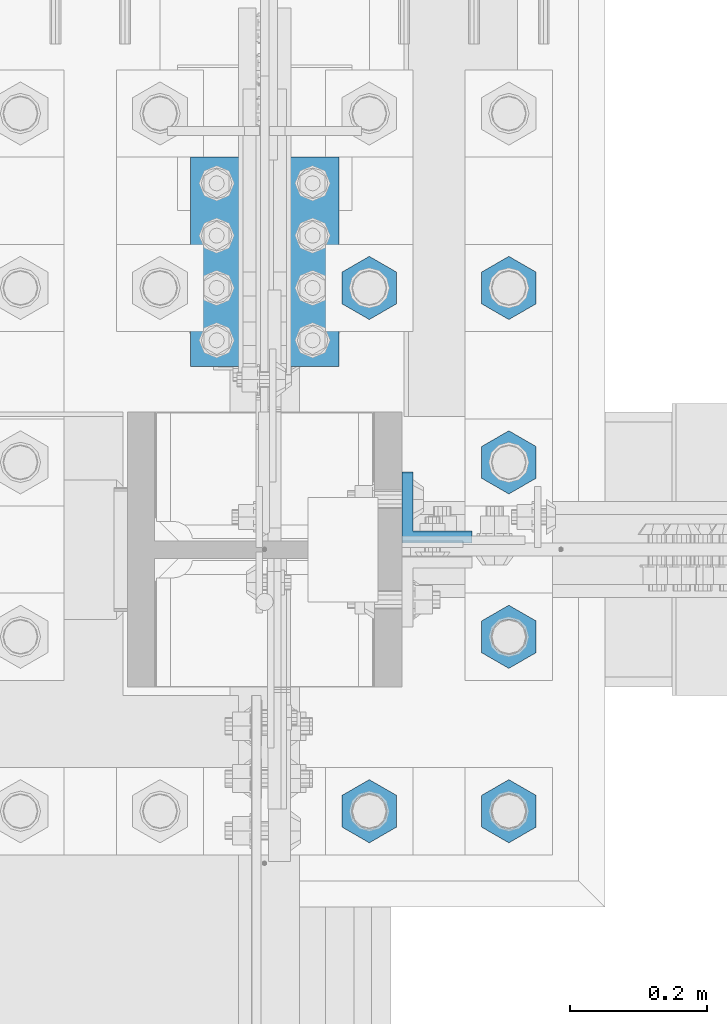
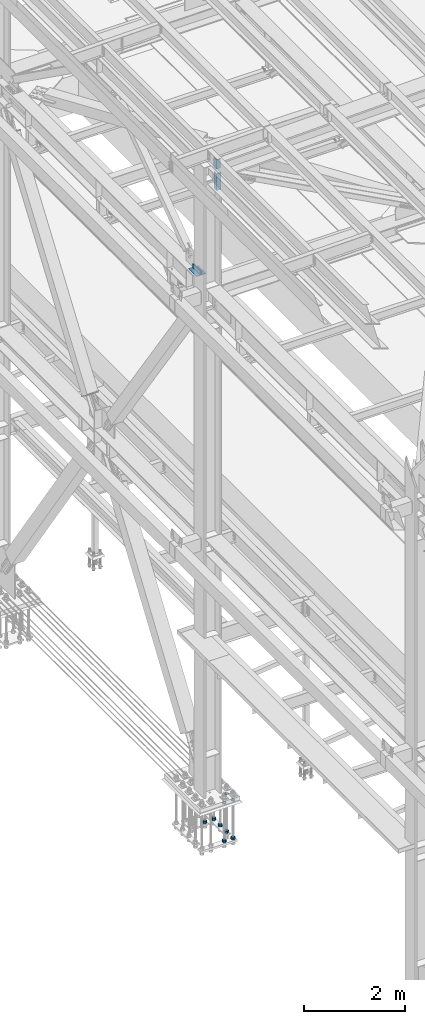
# One storey, part 2367 of 3843: 13 beams, 4 elements without a shape of their own.
"""IFC2X3 building model written with IfcOpenShell, lengths in millimetres."""

from ifc_helpers import new_model, si_unit, frame, origin_with_axes, place, context, subcontext, project, spatial, faceted_brep, material, type_object, element, aggregate, save


model = new_model("IFC2X3")

# Units and contexts
model_context = context("Model", 3, precision=1e-05, world=origin_with_axes())
body_context = subcontext(model_context, "Body", "Model", "MODEL_VIEW")
ifc_project = project(units=[si_unit("LENGTHUNIT", "METRE", prefix="MILLI"), si_unit("AREAUNIT", "SQUARE_METRE"), si_unit("VOLUMEUNIT", "CUBIC_METRE"), si_unit("MASSUNIT", "GRAM", prefix="KILO"), si_unit("TIMEUNIT", "SECOND"), si_unit("PLANEANGLEUNIT", "RADIAN"), si_unit("SOLIDANGLEUNIT", "STERADIAN"), si_unit("THERMODYNAMICTEMPERATUREUNIT", "DEGREE_CELSIUS"), si_unit("LUMINOUSINTENSITYUNIT", "LUMEN")], contexts=[model_context])

# Site, building, storey
site_placement = place(None, origin_with_axes())
site = spatial("IfcSite", under=ifc_project, at=site_placement, CompositionType="ELEMENT")
building_placement = place(site_placement, origin_with_axes())
building = spatial("IfcBuilding", under=site, at=building_placement, Name="Undefined", CompositionType="ELEMENT")
storey_placement = place(building_placement, origin_with_axes())
storey = spatial("IfcBuildingStorey", under=building, at=storey_placement, Name="Undefined", CompositionType="ELEMENT", Elevation=0.0)

# Assembly, beams
assembly_1_placement = place(storey_placement, origin_with_axes())
assembly_1 = element("IfcElementAssembly", 1, at=assembly_1_placement, inside=storey, Name="TEMPLATE", AssemblyPlace="NOTDEFINED", PredefinedType="RIGID_FRAME")
ifc_material = material(Name="STEEL/A572-50")
beam_type_1 = type_object("IfcBeamType", Name="2_HALF_NUT", PredefinedType="NOTDEFINED")
beam_1_placement = place(assembly_1_placement, frame((36931.6, 66890.9, 30060.9), z_axis=(-1.0, 0.0, 0.0), x_axis=(0.0, 0.0, -1.0)))
beam_1 = element("IfcBeam", 2, at=beam_1_placement, type_object=beam_type_1, material=ifc_material, Name="NUT", ObjectType="2_HALF_NUT", context=body_context, shape_type="Brep", body=[
    faceted_brep([(0.0, -46.0369987487793, 0.0), (0.0, -23.0184993743896, -39.869213104248), (25.4000000000015, -23.0184993743896, -39.869213104248), (25.4000000000015, -46.0369987487793, 0.0), (0.0, 23.0184993743896, -39.869213104248), (25.4000000000015, 23.0184993743896, -39.869213104248), (0.0, 46.0369987487793, 0.0), (25.4000000000015, 46.0369987487793, 0.0), (0.0, 23.0184993743896, 39.869213104248), (25.4000000000015, 23.0184993743896, 39.869213104248), (0.0, -23.0184993743896, 39.869213104248), (25.4000000000015, -23.0184993743896, 39.869213104248), (0.0, 0.0, 26.1940002441406), (0.0, 11.3650617044477, 23.5999013092805), (25.4000000000015, 11.3650617044477, 23.5999013092805), (25.4000000000015, 0.0, 26.1940002441406), (0.0, 20.4791109456419, 16.3316083006721), (25.4000000000015, 20.4791109456419, 16.3316083006721), (0.0, 25.5370200498292, 5.82867859874386), (25.4000000000015, 25.5370200498292, 5.82867859874386), (0.0, 25.5370200498292, -5.82867859874386), (25.4000000000015, 25.5370200498292, -5.82867859874386), (0.0, 20.4791109456419, -16.3316083006721), (25.4000000000015, 20.4791109456419, -16.3316083006721), (0.0, 11.3650617044477, -23.5999013092805), (25.4000000000015, 11.3650617044477, -23.5999013092805), (0.0, 0.0, -26.1940002441406), (25.4000000000015, 0.0, -26.1940002441406), (0.0, -11.3650617044477, -23.5999013092805), (25.4000000000015, -11.3650617044477, -23.5999013092805), (0.0, -20.4791109456419, -16.3316083006721), (25.4000000000015, -20.4791109456419, -16.3316083006721), (0.0, -25.5370200498292, -5.82867859874386), (25.4000000000015, -25.5370200498292, -5.82867859874386), (0.0, -25.5370200498292, 5.82867859874386), (25.4000000000015, -25.5370200498292, 5.82867859874386), (0.0, -20.4791109456419, 16.3316083006721), (25.4000000000015, -20.4791109456419, 16.3316083006721), (0.0, -11.3650617044477, 23.5999013092805), (25.4000000000015, -11.3650617044477, 23.5999013092805)], [[[0, 1, 2, 3]], [[1, 4, 5, 2]], [[4, 6, 7, 5]], [[6, 8, 9, 7]], [[8, 10, 11, 9]], [[10, 0, 3, 11]], [[12, 13, 14, 15]], [[13, 16, 17, 14]], [[16, 18, 19, 17]], [[18, 20, 21, 19]], [[20, 22, 23, 21]], [[22, 24, 25, 23]], [[24, 26, 27, 25]], [[26, 28, 29, 27]], [[28, 30, 31, 29]], [[30, 32, 33, 31]], [[32, 34, 35, 33]], [[34, 36, 37, 35]], [[36, 38, 39, 37]], [[38, 12, 15, 39]], [[5, 7, 9, 11, 3, 2], [17, 19, 21, 23, 25, 27, 29, 31, 33, 35, 37, 39, 15, 14]], [[10, 8, 6, 4, 1, 0], [38, 36, 34, 32, 30, 28, 26, 24, 22, 20, 18, 16, 13, 12]]]),
])
beam_2_placement = place(assembly_1_placement, frame((36728.4, 66890.9, 30060.9), z_axis=(-1.0, 0.0, 0.0), x_axis=(0.0, 0.0, -1.0)))
beam_2 = element("IfcBeam", 3, at=beam_2_placement, type_object=beam_type_1, material=ifc_material, Name="NUT", ObjectType="2_HALF_NUT", context=body_context, shape_type="Brep", body=[
    faceted_brep([(0.0, -46.0369987487793, 0.0), (0.0, -23.0184993743896, -39.869213104248), (25.4000000000015, -23.0184993743896, -39.869213104248), (25.4000000000015, -46.0369987487793, 0.0), (0.0, 23.0184993743896, -39.869213104248), (25.4000000000015, 23.0184993743896, -39.869213104248), (0.0, 46.0369987487793, 0.0), (25.4000000000015, 46.0369987487793, 0.0), (0.0, 23.0184993743896, 39.869213104248), (25.4000000000015, 23.0184993743896, 39.869213104248), (0.0, -23.0184993743896, 39.869213104248), (25.4000000000015, -23.0184993743896, 39.869213104248), (0.0, 0.0, 26.1940002441406), (0.0, 11.3650617044477, 23.5999013092805), (25.4000000000015, 11.3650617044477, 23.5999013092805), (25.4000000000015, 0.0, 26.1940002441406), (0.0, 20.4791109456419, 16.3316083006721), (25.4000000000015, 20.4791109456419, 16.3316083006721), (0.0, 25.5370200498292, 5.82867859874386), (25.4000000000015, 25.5370200498292, 5.82867859874386), (0.0, 25.5370200498292, -5.82867859874386), (25.4000000000015, 25.5370200498292, -5.82867859874386), (0.0, 20.4791109456419, -16.3316083006721), (25.4000000000015, 20.4791109456419, -16.3316083006721), (0.0, 11.3650617044477, -23.5999013092805), (25.4000000000015, 11.3650617044477, -23.5999013092805), (0.0, 0.0, -26.1940002441406), (25.4000000000015, 0.0, -26.1940002441406), (0.0, -11.3650617044477, -23.5999013092805), (25.4000000000015, -11.3650617044477, -23.5999013092805), (0.0, -20.4791109456419, -16.3316083006721), (25.4000000000015, -20.4791109456419, -16.3316083006721), (0.0, -25.5370200498292, -5.82867859874386), (25.4000000000015, -25.5370200498292, -5.82867859874386), (0.0, -25.5370200498292, 5.82867859874386), (25.4000000000015, -25.5370200498292, 5.82867859874386), (0.0, -20.4791109456419, 16.3316083006721), (25.4000000000015, -20.4791109456419, 16.3316083006721), (0.0, -11.3650617044477, 23.5999013092805), (25.4000000000015, -11.3650617044477, 23.5999013092805)], [[[0, 1, 2, 3]], [[1, 4, 5, 2]], [[4, 6, 7, 5]], [[6, 8, 9, 7]], [[8, 10, 11, 9]], [[10, 0, 3, 11]], [[12, 13, 14, 15]], [[13, 16, 17, 14]], [[16, 18, 19, 17]], [[18, 20, 21, 19]], [[20, 22, 23, 21]], [[22, 24, 25, 23]], [[24, 26, 27, 25]], [[26, 28, 29, 27]], [[28, 30, 31, 29]], [[30, 32, 33, 31]], [[32, 34, 35, 33]], [[34, 36, 37, 35]], [[36, 38, 39, 37]], [[38, 12, 15, 39]], [[5, 7, 9, 11, 3, 2], [17, 19, 21, 23, 25, 27, 29, 31, 33, 35, 37, 39, 15, 14]], [[10, 8, 6, 4, 1, 0], [38, 36, 34, 32, 30, 28, 26, 24, 22, 20, 18, 16, 13, 12]]]),
])
beam_3_placement = place(assembly_1_placement, frame((36931.6, 67144.9, 30060.9), z_axis=(-1.0, 0.0, 0.0), x_axis=(0.0, 0.0, -1.0)))
beam_3 = element("IfcBeam", 4, at=beam_3_placement, type_object=beam_type_1, material=ifc_material, Name="NUT", ObjectType="2_HALF_NUT", context=body_context, shape_type="Brep", body=[
    faceted_brep([(0.0, -46.0369987487793, 0.0), (0.0, -23.0184993743896, -39.869213104248), (25.4000000000015, -23.0184993743896, -39.869213104248), (25.4000000000015, -46.0369987487793, 0.0), (0.0, 23.0184993743896, -39.869213104248), (25.4000000000015, 23.0184993743896, -39.869213104248), (0.0, 46.0369987487793, 0.0), (25.4000000000015, 46.0369987487793, 0.0), (0.0, 23.0184993743896, 39.869213104248), (25.4000000000015, 23.0184993743896, 39.869213104248), (0.0, -23.0184993743896, 39.869213104248), (25.4000000000015, -23.0184993743896, 39.869213104248), (0.0, 0.0, 26.1940002441406), (0.0, 11.3650617044477, 23.5999013092805), (25.4000000000015, 11.3650617044477, 23.5999013092805), (25.4000000000015, 0.0, 26.1940002441406), (0.0, 20.4791109456419, 16.3316083006721), (25.4000000000015, 20.4791109456419, 16.3316083006721), (0.0, 25.5370200498292, 5.82867859874386), (25.4000000000015, 25.5370200498292, 5.82867859874386), (0.0, 25.5370200498292, -5.82867859874386), (25.4000000000015, 25.5370200498292, -5.82867859874386), (0.0, 20.4791109456419, -16.3316083006721), (25.4000000000015, 20.4791109456419, -16.3316083006721), (0.0, 11.3650617044477, -23.5999013092805), (25.4000000000015, 11.3650617044477, -23.5999013092805), (0.0, 0.0, -26.1940002441406), (25.4000000000015, 0.0, -26.1940002441406), (0.0, -11.3650617044477, -23.5999013092805), (25.4000000000015, -11.3650617044477, -23.5999013092805), (0.0, -20.4791109456419, -16.3316083006721), (25.4000000000015, -20.4791109456419, -16.3316083006721), (0.0, -25.5370200498292, -5.82867859874386), (25.4000000000015, -25.5370200498292, -5.82867859874386), (0.0, -25.5370200498292, 5.82867859874386), (25.4000000000015, -25.5370200498292, 5.82867859874386), (0.0, -20.4791109456419, 16.3316083006721), (25.4000000000015, -20.4791109456419, 16.3316083006721), (0.0, -11.3650617044477, 23.5999013092805), (25.4000000000015, -11.3650617044477, 23.5999013092805)], [[[0, 1, 2, 3]], [[1, 4, 5, 2]], [[4, 6, 7, 5]], [[6, 8, 9, 7]], [[8, 10, 11, 9]], [[10, 0, 3, 11]], [[12, 13, 14, 15]], [[13, 16, 17, 14]], [[16, 18, 19, 17]], [[18, 20, 21, 19]], [[20, 22, 23, 21]], [[22, 24, 25, 23]], [[24, 26, 27, 25]], [[26, 28, 29, 27]], [[28, 30, 31, 29]], [[30, 32, 33, 31]], [[32, 34, 35, 33]], [[34, 36, 37, 35]], [[36, 38, 39, 37]], [[38, 12, 15, 39]], [[5, 7, 9, 11, 3, 2], [17, 19, 21, 23, 25, 27, 29, 31, 33, 35, 37, 39, 15, 14]], [[10, 8, 6, 4, 1, 0], [38, 36, 34, 32, 30, 28, 26, 24, 22, 20, 18, 16, 13, 12]]]),
])
beam_type_2 = type_object("IfcBeamType", Name="2_HEAVY_HEX_NUT", PredefinedType="NOTDEFINED")
beam_4_placement = place(assembly_1_placement, frame((36931.6, 66890.9, 29159.2), z_axis=(1.0, 0.0, 0.0), x_axis=(0.0, 0.0, -1.0)))
beam_4 = element("IfcBeam", 5, at=beam_4_placement, type_object=beam_type_2, material=ifc_material, Name="NUT", ObjectType="2_HEAVY_HEX_NUT", context=body_context, shape_type="Brep", body=[
    faceted_brep([(0.0, -46.0369987487793, 0.0), (0.0, -23.0184993743896, -39.869213104248), (50.7999999999993, -23.0184993743896, -39.869213104248), (50.7999999999993, -46.0369987487793, 0.0), (0.0, 23.0184993743896, -39.869213104248), (50.7999999999993, 23.0184993743896, -39.869213104248), (0.0, 46.0369987487793, 0.0), (50.7999999999993, 46.0369987487793, 0.0), (0.0, 23.0184993743896, 39.869213104248), (50.7999999999993, 23.0184993743896, 39.869213104248), (0.0, -23.0184993743896, 39.869213104248), (50.7999999999993, -23.0184993743896, 39.869213104248), (0.0, 0.0, 26.1940002441406), (0.0, 11.3650617044477, 23.5999013092805), (50.7999999999993, 11.3650617044477, 23.5999013092805), (50.7999999999993, 0.0, 26.1940002441406), (0.0, 20.4791109456419, 16.3316083006721), (50.7999999999993, 20.4791109456419, 16.3316083006721), (0.0, 25.5370200498292, 5.82867859874386), (50.7999999999993, 25.5370200498292, 5.82867859874386), (0.0, 25.5370200498292, -5.82867859874386), (50.7999999999993, 25.5370200498292, -5.82867859874386), (0.0, 20.4791109456419, -16.3316083006721), (50.7999999999993, 20.4791109456419, -16.3316083006721), (0.0, 11.3650617044477, -23.5999013092805), (50.7999999999993, 11.3650617044477, -23.5999013092805), (0.0, 0.0, -26.1940002441406), (50.7999999999993, 0.0, -26.1940002441406), (0.0, -11.3650617044477, -23.5999013092805), (50.7999999999993, -11.3650617044477, -23.5999013092805), (0.0, -20.4791109456419, -16.3316083006721), (50.7999999999993, -20.4791109456419, -16.3316083006721), (0.0, -25.5370200498292, -5.82867859874386), (50.7999999999993, -25.5370200498292, -5.82867859874386), (0.0, -25.5370200498292, 5.82867859874386), (50.7999999999993, -25.5370200498292, 5.82867859874386), (0.0, -20.4791109456419, 16.3316083006721), (50.7999999999993, -20.4791109456419, 16.3316083006721), (0.0, -11.3650617044477, 23.5999013092805), (50.7999999999993, -11.3650617044477, 23.5999013092805)], [[[0, 1, 2, 3]], [[1, 4, 5, 2]], [[4, 6, 7, 5]], [[6, 8, 9, 7]], [[8, 10, 11, 9]], [[10, 0, 3, 11]], [[12, 13, 14, 15]], [[13, 16, 17, 14]], [[16, 18, 19, 17]], [[18, 20, 21, 19]], [[20, 22, 23, 21]], [[22, 24, 25, 23]], [[24, 26, 27, 25]], [[26, 28, 29, 27]], [[28, 30, 31, 29]], [[30, 32, 33, 31]], [[32, 34, 35, 33]], [[34, 36, 37, 35]], [[36, 38, 39, 37]], [[38, 12, 15, 39]], [[5, 7, 9, 11, 3, 2], [17, 19, 21, 23, 25, 27, 29, 31, 33, 35, 37, 39, 15, 14]], [[10, 8, 6, 4, 1, 0], [38, 36, 34, 32, 30, 28, 26, 24, 22, 20, 18, 16, 13, 12]]]),
])
beam_5_placement = place(assembly_1_placement, frame((36728.4, 66890.9, 29159.2), z_axis=(1.0, 0.0, 0.0), x_axis=(0.0, 0.0, -1.0)))
beam_5 = element("IfcBeam", 6, at=beam_5_placement, type_object=beam_type_2, material=ifc_material, Name="NUT", ObjectType="2_HEAVY_HEX_NUT", context=body_context, shape_type="Brep", body=[
    faceted_brep([(0.0, -46.0369987487793, 0.0), (0.0, -23.0184993743896, -39.869213104248), (50.7999999999993, -23.0184993743896, -39.869213104248), (50.7999999999993, -46.0369987487793, 0.0), (0.0, 23.0184993743896, -39.869213104248), (50.7999999999993, 23.0184993743896, -39.869213104248), (0.0, 46.0369987487793, 0.0), (50.7999999999993, 46.0369987487793, 0.0), (0.0, 23.0184993743896, 39.869213104248), (50.7999999999993, 23.0184993743896, 39.869213104248), (0.0, -23.0184993743896, 39.869213104248), (50.7999999999993, -23.0184993743896, 39.869213104248), (0.0, 0.0, 26.1940002441406), (0.0, 11.3650617044477, 23.5999013092805), (50.7999999999993, 11.3650617044477, 23.5999013092805), (50.7999999999993, 0.0, 26.1940002441406), (0.0, 20.4791109456419, 16.3316083006721), (50.7999999999993, 20.4791109456419, 16.3316083006721), (0.0, 25.5370200498292, 5.82867859874386), (50.7999999999993, 25.5370200498292, 5.82867859874386), (0.0, 25.5370200498292, -5.82867859874386), (50.7999999999993, 25.5370200498292, -5.82867859874386), (0.0, 20.4791109456419, -16.3316083006721), (50.7999999999993, 20.4791109456419, -16.3316083006721), (0.0, 11.3650617044477, -23.5999013092805), (50.7999999999993, 11.3650617044477, -23.5999013092805), (0.0, 0.0, -26.1940002441406), (50.7999999999993, 0.0, -26.1940002441406), (0.0, -11.3650617044477, -23.5999013092805), (50.7999999999993, -11.3650617044477, -23.5999013092805), (0.0, -20.4791109456419, -16.3316083006721), (50.7999999999993, -20.4791109456419, -16.3316083006721), (0.0, -25.5370200498292, -5.82867859874386), (50.7999999999993, -25.5370200498292, -5.82867859874386), (0.0, -25.5370200498292, 5.82867859874386), (50.7999999999993, -25.5370200498292, 5.82867859874386), (0.0, -20.4791109456419, 16.3316083006721), (50.7999999999993, -20.4791109456419, 16.3316083006721), (0.0, -11.3650617044477, 23.5999013092805), (50.7999999999993, -11.3650617044477, 23.5999013092805)], [[[0, 1, 2, 3]], [[1, 4, 5, 2]], [[4, 6, 7, 5]], [[6, 8, 9, 7]], [[8, 10, 11, 9]], [[10, 0, 3, 11]], [[12, 13, 14, 15]], [[13, 16, 17, 14]], [[16, 18, 19, 17]], [[18, 20, 21, 19]], [[20, 22, 23, 21]], [[22, 24, 25, 23]], [[24, 26, 27, 25]], [[26, 28, 29, 27]], [[28, 30, 31, 29]], [[30, 32, 33, 31]], [[32, 34, 35, 33]], [[34, 36, 37, 35]], [[36, 38, 39, 37]], [[38, 12, 15, 39]], [[5, 7, 9, 11, 3, 2], [17, 19, 21, 23, 25, 27, 29, 31, 33, 35, 37, 39, 15, 14]], [[10, 8, 6, 4, 1, 0], [38, 36, 34, 32, 30, 28, 26, 24, 22, 20, 18, 16, 13, 12]]]),
])
beam_6_placement = place(assembly_1_placement, frame((36728.4, 67652.9, 29159.2), z_axis=(-1.0, 0.0, 0.0), x_axis=(0.0, 0.0, -1.0)))
beam_6 = element("IfcBeam", 7, at=beam_6_placement, type_object=beam_type_2, material=ifc_material, Name="NUT", ObjectType="2_HEAVY_HEX_NUT", context=body_context, shape_type="Brep", body=[
    faceted_brep([(0.0, -46.0369987487793, 0.0), (0.0, -23.0184993743896, -39.869213104248), (50.7999999999993, -23.0184993743896, -39.869213104248), (50.7999999999993, -46.0369987487793, 0.0), (0.0, 23.0184993743896, -39.869213104248), (50.7999999999993, 23.0184993743896, -39.869213104248), (0.0, 46.0369987487793, 0.0), (50.7999999999993, 46.0369987487793, 0.0), (0.0, 23.0184993743896, 39.869213104248), (50.7999999999993, 23.0184993743896, 39.869213104248), (0.0, -23.0184993743896, 39.869213104248), (50.7999999999993, -23.0184993743896, 39.869213104248), (0.0, 0.0, 26.1940002441406), (0.0, 11.3650617044477, 23.5999013092805), (50.7999999999993, 11.3650617044477, 23.5999013092805), (50.7999999999993, 0.0, 26.1940002441406), (0.0, 20.4791109456419, 16.3316083006721), (50.7999999999993, 20.4791109456419, 16.3316083006721), (0.0, 25.5370200498292, 5.82867859874386), (50.7999999999993, 25.5370200498292, 5.82867859874386), (0.0, 25.5370200498292, -5.82867859874386), (50.7999999999993, 25.5370200498292, -5.82867859874386), (0.0, 20.4791109456419, -16.3316083006721), (50.7999999999993, 20.4791109456419, -16.3316083006721), (0.0, 11.3650617044477, -23.5999013092805), (50.7999999999993, 11.3650617044477, -23.5999013092805), (0.0, 0.0, -26.1940002441406), (50.7999999999993, 0.0, -26.1940002441406), (0.0, -11.3650617044477, -23.5999013092805), (50.7999999999993, -11.3650617044477, -23.5999013092805), (0.0, -20.4791109456419, -16.3316083006721), (50.7999999999993, -20.4791109456419, -16.3316083006721), (0.0, -25.5370200498292, -5.82867859874386), (50.7999999999993, -25.5370200498292, -5.82867859874386), (0.0, -25.5370200498292, 5.82867859874386), (50.7999999999993, -25.5370200498292, 5.82867859874386), (0.0, -20.4791109456419, 16.3316083006721), (50.7999999999993, -20.4791109456419, 16.3316083006721), (0.0, -11.3650617044477, 23.5999013092805), (50.7999999999993, -11.3650617044477, 23.5999013092805)], [[[0, 1, 2, 3]], [[1, 4, 5, 2]], [[4, 6, 7, 5]], [[6, 8, 9, 7]], [[8, 10, 11, 9]], [[10, 0, 3, 11]], [[12, 13, 14, 15]], [[13, 16, 17, 14]], [[16, 18, 19, 17]], [[18, 20, 21, 19]], [[20, 22, 23, 21]], [[22, 24, 25, 23]], [[24, 26, 27, 25]], [[26, 28, 29, 27]], [[28, 30, 31, 29]], [[30, 32, 33, 31]], [[32, 34, 35, 33]], [[34, 36, 37, 35]], [[36, 38, 39, 37]], [[38, 12, 15, 39]], [[5, 7, 9, 11, 3, 2], [17, 19, 21, 23, 25, 27, 29, 31, 33, 35, 37, 39, 15, 14]], [[10, 8, 6, 4, 1, 0], [38, 36, 34, 32, 30, 28, 26, 24, 22, 20, 18, 16, 13, 12]]]),
])
beam_7_placement = place(assembly_1_placement, frame((36931.6, 67144.9, 29159.2), z_axis=(1.0, 0.0, 0.0), x_axis=(0.0, 0.0, -1.0)))
beam_7 = element("IfcBeam", 8, at=beam_7_placement, type_object=beam_type_2, material=ifc_material, Name="NUT", ObjectType="2_HEAVY_HEX_NUT", context=body_context, shape_type="Brep", body=[
    faceted_brep([(0.0, -46.0369987487793, 0.0), (0.0, -23.0184993743896, -39.869213104248), (50.7999999999993, -23.0184993743896, -39.869213104248), (50.7999999999993, -46.0369987487793, 0.0), (0.0, 23.0184993743896, -39.869213104248), (50.7999999999993, 23.0184993743896, -39.869213104248), (0.0, 46.0369987487793, 0.0), (50.7999999999993, 46.0369987487793, 0.0), (0.0, 23.0184993743896, 39.869213104248), (50.7999999999993, 23.0184993743896, 39.869213104248), (0.0, -23.0184993743896, 39.869213104248), (50.7999999999993, -23.0184993743896, 39.869213104248), (0.0, 0.0, 26.1940002441406), (0.0, 11.3650617044477, 23.5999013092805), (50.7999999999993, 11.3650617044477, 23.5999013092805), (50.7999999999993, 0.0, 26.1940002441406), (0.0, 20.4791109456419, 16.3316083006721), (50.7999999999993, 20.4791109456419, 16.3316083006721), (0.0, 25.5370200498292, 5.82867859874386), (50.7999999999993, 25.5370200498292, 5.82867859874386), (0.0, 25.5370200498292, -5.82867859874386), (50.7999999999993, 25.5370200498292, -5.82867859874386), (0.0, 20.4791109456419, -16.3316083006721), (50.7999999999993, 20.4791109456419, -16.3316083006721), (0.0, 11.3650617044477, -23.5999013092805), (50.7999999999993, 11.3650617044477, -23.5999013092805), (0.0, 0.0, -26.1940002441406), (50.7999999999993, 0.0, -26.1940002441406), (0.0, -11.3650617044477, -23.5999013092805), (50.7999999999993, -11.3650617044477, -23.5999013092805), (0.0, -20.4791109456419, -16.3316083006721), (50.7999999999993, -20.4791109456419, -16.3316083006721), (0.0, -25.5370200498292, -5.82867859874386), (50.7999999999993, -25.5370200498292, -5.82867859874386), (0.0, -25.5370200498292, 5.82867859874386), (50.7999999999993, -25.5370200498292, 5.82867859874386), (0.0, -20.4791109456419, 16.3316083006721), (50.7999999999993, -20.4791109456419, 16.3316083006721), (0.0, -11.3650617044477, 23.5999013092805), (50.7999999999993, -11.3650617044477, 23.5999013092805)], [[[0, 1, 2, 3]], [[1, 4, 5, 2]], [[4, 6, 7, 5]], [[6, 8, 9, 7]], [[8, 10, 11, 9]], [[10, 0, 3, 11]], [[12, 13, 14, 15]], [[13, 16, 17, 14]], [[16, 18, 19, 17]], [[18, 20, 21, 19]], [[20, 22, 23, 21]], [[22, 24, 25, 23]], [[24, 26, 27, 25]], [[26, 28, 29, 27]], [[28, 30, 31, 29]], [[30, 32, 33, 31]], [[32, 34, 35, 33]], [[34, 36, 37, 35]], [[36, 38, 39, 37]], [[38, 12, 15, 39]], [[5, 7, 9, 11, 3, 2], [17, 19, 21, 23, 25, 27, 29, 31, 33, 35, 37, 39, 15, 14]], [[10, 8, 6, 4, 1, 0], [38, 36, 34, 32, 30, 28, 26, 24, 22, 20, 18, 16, 13, 12]]]),
])
beam_8_placement = place(assembly_1_placement, frame((36931.6, 67398.9, 29159.2), z_axis=(1.0, 0.0, 0.0), x_axis=(0.0, 0.0, -1.0)))
beam_8 = element("IfcBeam", 9, at=beam_8_placement, type_object=beam_type_2, material=ifc_material, Name="NUT", ObjectType="2_HEAVY_HEX_NUT", context=body_context, shape_type="Brep", body=[
    faceted_brep([(0.0, -46.0369987487793, 0.0), (0.0, -23.0184993743896, -39.869213104248), (50.7999999999993, -23.0184993743896, -39.869213104248), (50.7999999999993, -46.0369987487793, 0.0), (0.0, 23.0184993743896, -39.869213104248), (50.7999999999993, 23.0184993743896, -39.869213104248), (0.0, 46.0369987487793, 0.0), (50.7999999999993, 46.0369987487793, 0.0), (0.0, 23.0184993743896, 39.869213104248), (50.7999999999993, 23.0184993743896, 39.869213104248), (0.0, -23.0184993743896, 39.869213104248), (50.7999999999993, -23.0184993743896, 39.869213104248), (0.0, 0.0, 26.1940002441406), (0.0, 11.3650617044477, 23.5999013092805), (50.7999999999993, 11.3650617044477, 23.5999013092805), (50.7999999999993, 0.0, 26.1940002441406), (0.0, 20.4791109456419, 16.3316083006721), (50.7999999999993, 20.4791109456419, 16.3316083006721), (0.0, 25.5370200498292, 5.82867859874386), (50.7999999999993, 25.5370200498292, 5.82867859874386), (0.0, 25.5370200498292, -5.82867859874386), (50.7999999999993, 25.5370200498292, -5.82867859874386), (0.0, 20.4791109456419, -16.3316083006721), (50.7999999999993, 20.4791109456419, -16.3316083006721), (0.0, 11.3650617044477, -23.5999013092805), (50.7999999999993, 11.3650617044477, -23.5999013092805), (0.0, 0.0, -26.1940002441406), (50.7999999999993, 0.0, -26.1940002441406), (0.0, -11.3650617044477, -23.5999013092805), (50.7999999999993, -11.3650617044477, -23.5999013092805), (0.0, -20.4791109456419, -16.3316083006721), (50.7999999999993, -20.4791109456419, -16.3316083006721), (0.0, -25.5370200498292, -5.82867859874386), (50.7999999999993, -25.5370200498292, -5.82867859874386), (0.0, -25.5370200498292, 5.82867859874386), (50.7999999999993, -25.5370200498292, 5.82867859874386), (0.0, -20.4791109456419, 16.3316083006721), (50.7999999999993, -20.4791109456419, 16.3316083006721), (0.0, -11.3650617044477, 23.5999013092805), (50.7999999999993, -11.3650617044477, 23.5999013092805)], [[[0, 1, 2, 3]], [[1, 4, 5, 2]], [[4, 6, 7, 5]], [[6, 8, 9, 7]], [[8, 10, 11, 9]], [[10, 0, 3, 11]], [[12, 13, 14, 15]], [[13, 16, 17, 14]], [[16, 18, 19, 17]], [[18, 20, 21, 19]], [[20, 22, 23, 21]], [[22, 24, 25, 23]], [[24, 26, 27, 25]], [[26, 28, 29, 27]], [[28, 30, 31, 29]], [[30, 32, 33, 31]], [[32, 34, 35, 33]], [[34, 36, 37, 35]], [[36, 38, 39, 37]], [[38, 12, 15, 39]], [[5, 7, 9, 11, 3, 2], [17, 19, 21, 23, 25, 27, 29, 31, 33, 35, 37, 39, 15, 14]], [[10, 8, 6, 4, 1, 0], [38, 36, 34, 32, 30, 28, 26, 24, 22, 20, 18, 16, 13, 12]]]),
])
beam_9_placement = place(assembly_1_placement, frame((36931.6, 67652.9, 29159.2), z_axis=(-1.0, 0.0, 0.0), x_axis=(0.0, 0.0, -1.0)))
beam_9 = element("IfcBeam", 10, at=beam_9_placement, type_object=beam_type_2, material=ifc_material, Name="NUT", ObjectType="2_HEAVY_HEX_NUT", context=body_context, shape_type="Brep", body=[
    faceted_brep([(0.0, -46.0369987487793, 0.0), (0.0, -23.0184993743896, -39.869213104248), (50.7999999999993, -23.0184993743896, -39.869213104248), (50.7999999999993, -46.0369987487793, 0.0), (0.0, 23.0184993743896, -39.869213104248), (50.7999999999993, 23.0184993743896, -39.869213104248), (0.0, 46.0369987487793, 0.0), (50.7999999999993, 46.0369987487793, 0.0), (0.0, 23.0184993743896, 39.869213104248), (50.7999999999993, 23.0184993743896, 39.869213104248), (0.0, -23.0184993743896, 39.869213104248), (50.7999999999993, -23.0184993743896, 39.869213104248), (0.0, 0.0, 26.1940002441406), (0.0, 11.3650617044477, 23.5999013092805), (50.7999999999993, 11.3650617044477, 23.5999013092805), (50.7999999999993, 0.0, 26.1940002441406), (0.0, 20.4791109456419, 16.3316083006721), (50.7999999999993, 20.4791109456419, 16.3316083006721), (0.0, 25.5370200498292, 5.82867859874386), (50.7999999999993, 25.5370200498292, 5.82867859874386), (0.0, 25.5370200498292, -5.82867859874386), (50.7999999999993, 25.5370200498292, -5.82867859874386), (0.0, 20.4791109456419, -16.3316083006721), (50.7999999999993, 20.4791109456419, -16.3316083006721), (0.0, 11.3650617044477, -23.5999013092805), (50.7999999999993, 11.3650617044477, -23.5999013092805), (0.0, 0.0, -26.1940002441406), (50.7999999999993, 0.0, -26.1940002441406), (0.0, -11.3650617044477, -23.5999013092805), (50.7999999999993, -11.3650617044477, -23.5999013092805), (0.0, -20.4791109456419, -16.3316083006721), (50.7999999999993, -20.4791109456419, -16.3316083006721), (0.0, -25.5370200498292, -5.82867859874386), (50.7999999999993, -25.5370200498292, -5.82867859874386), (0.0, -25.5370200498292, 5.82867859874386), (50.7999999999993, -25.5370200498292, 5.82867859874386), (0.0, -20.4791109456419, 16.3316083006721), (50.7999999999993, -20.4791109456419, 16.3316083006721), (0.0, -11.3650617044477, 23.5999013092805), (50.7999999999993, -11.3650617044477, 23.5999013092805)], [[[0, 1, 2, 3]], [[1, 4, 5, 2]], [[4, 6, 7, 5]], [[6, 8, 9, 7]], [[8, 10, 11, 9]], [[10, 0, 3, 11]], [[12, 13, 14, 15]], [[13, 16, 17, 14]], [[16, 18, 19, 17]], [[18, 20, 21, 19]], [[20, 22, 23, 21]], [[22, 24, 25, 23]], [[24, 26, 27, 25]], [[26, 28, 29, 27]], [[28, 30, 31, 29]], [[30, 32, 33, 31]], [[32, 34, 35, 33]], [[34, 36, 37, 35]], [[36, 38, 39, 37]], [[38, 12, 15, 39]], [[5, 7, 9, 11, 3, 2], [17, 19, 21, 23, 25, 27, 29, 31, 33, 35, 37, 39, 15, 14]], [[10, 8, 6, 4, 1, 0], [38, 36, 34, 32, 30, 28, 26, 24, 22, 20, 18, 16, 13, 12]]]),
])
aggregate(assembly_1, [beam_4, beam_5, beam_6, beam_7, beam_8, beam_9, beam_1, beam_2, beam_3])

# Assembly, beam
assembly_2_placement = place(storey_placement, origin_with_axes())
assembly_2 = element("IfcElementAssembly", 11, at=assembly_2_placement, inside=storey, Name="ANGLE", AssemblyPlace="NOTDEFINED", PredefinedType="RIGID_FRAME")
beam_type_3 = type_object("IfcBeamType", Name="L4X4X3/8", PredefinedType="NOTDEFINED")
beam_10_placement = place(assembly_2_placement, frame((36633.1500000077, 67538.6000000008, 42519.6000000014), z_axis=(0.0, 0.0, 1.0), x_axis=(0.0, 1.0, 0.0)))
beam_10 = element("IfcBeam", 12, at=beam_10_placement, type_object=beam_type_3, material=ifc_material, Name="ANGLE", ObjectType="L4X4X3/8", context=body_context, shape_type="Brep", body=[
    faceted_brep([(0.0, 50.8000000000029, -50.8000000000029), (0.0, 50.8000000000029, 50.8000000000029), (304.800000000003, 50.8000000000029, 50.8000000000029), (304.800000000003, 50.8000000000029, -50.8000000000029), (0.0, 41.2750000000015, 50.8000000000029), (304.800000000003, 41.2749999999942, 50.8000000000029), (0.0, 41.2749999999942, -41.2750000000015), (304.800000000003, 41.2749999999942, -41.2750000000015), (0.0, -50.8000000000029, -41.2750000000015), (304.800000000003, -50.8000000000029, -41.2750000000015), (0.0, -50.8000000000029, -50.8000000000029), (304.800000000003, -50.8000000000029, -50.8000000000029)], [[[0, 1, 2, 3]], [[1, 4, 5, 2]], [[4, 6, 7, 5]], [[6, 8, 9, 7]], [[8, 10, 11, 9]], [[10, 0, 3, 11]], [[5, 7, 9, 11, 3, 2]], [[10, 8, 6, 4, 1, 0]]]),
])
aggregate(assembly_2, [beam_10])

assembly_3_placement = place(storey_placement, origin_with_axes())
assembly_3 = element("IfcElementAssembly", 13, at=assembly_3_placement, inside=storey, Name="ANGLE", AssemblyPlace="NOTDEFINED", PredefinedType="RIGID_FRAME")
beam_11_placement = place(assembly_3_placement, frame((36518.8500000077, 67843.4000000008, 42519.6000000014), z_axis=(0.0, 0.0, 1.0), x_axis=(0.0, -1.0, 0.0)))
beam_11 = element("IfcBeam", 14, at=beam_11_placement, type_object=beam_type_3, material=ifc_material, Name="ANGLE", ObjectType="L4X4X3/8", context=body_context, shape_type="Brep", body=[
    faceted_brep([(0.0, 50.8000000000029, -50.8000000000029), (0.0, 50.8000000000029, 50.8000000000029), (304.800000000003, 50.8000000000029, 50.8000000000029), (304.800000000003, 50.8000000000029, -50.8000000000029), (0.0, 41.2750000000015, 50.8000000000029), (304.800000000003, 41.2749999999942, 50.8000000000029), (0.0, 41.2749999999942, -41.2750000000015), (304.800000000003, 41.2749999999942, -41.2750000000015), (0.0, -50.8000000000029, -41.2750000000015), (304.800000000003, -50.8000000000029, -41.2750000000015), (0.0, -50.8000000000029, -50.8000000000029), (304.800000000003, -50.8000000000029, -50.8000000000029)], [[[0, 1, 2, 3]], [[1, 4, 5, 2]], [[4, 6, 7, 5]], [[6, 8, 9, 7]], [[8, 10, 11, 9]], [[10, 0, 3, 11]], [[5, 7, 9, 11, 3, 2]], [[10, 8, 6, 4, 1, 0]]]),
])
aggregate(assembly_3, [beam_11])

# Assembly, beams
assembly_4_placement = place(storey_placement, origin_with_axes())
assembly_4 = element("IfcElementAssembly", 15, at=assembly_4_placement, inside=storey, Name="BEAM", AssemblyPlace="NOTDEFINED", PredefinedType="RIGID_FRAME")
beam_type_4 = type_object("IfcBeamType", Name="L4X4X5/8", PredefinedType="NOTDEFINED")
beam_12_placement = place(assembly_4_placement, frame((36826.8250000141, 67333.8120004654, 45342.1469176929), z_axis=(0.0, 1.0, 0.0), x_axis=(0.0, 0.0, -1.0)))
beam_12 = element("IfcBeam", 16, at=beam_12_placement, type_object=beam_type_4, material=ifc_material, Name="ANGLE", ObjectType="L4X4X5/8", context=body_context, shape_type="Brep", body=[
    faceted_brep([(0.0, 50.8000000000029, -50.8000000000029), (0.0, 50.8000000000029, 50.8000000000029), (228.600164820818, 50.8000000000029, 50.8000000000029), (228.600164820818, 50.8000000000029, -50.8000000000029), (0.0, 34.9250000000029, 50.8000000000029), (228.600164820818, 34.9250000000029, 50.8000000000029), (0.0, 34.9250000000029, -34.9250000000029), (228.600164820818, 34.9250000000029, -34.9250000000029), (0.0, -50.8000000000029, -34.9250000000029), (228.600164820818, -50.8000000000029, -34.9250000000029), (0.0, -50.8000000000029, -50.8000000000029), (228.600164820818, -50.8000000000029, -50.8000000000029)], [[[0, 1, 2, 3]], [[1, 4, 5, 2]], [[4, 6, 7, 5]], [[6, 8, 9, 7]], [[8, 10, 11, 9]], [[10, 0, 3, 11]], [[5, 7, 9, 11, 3, 2]], [[10, 8, 6, 4, 1, 0]]]),
])
beam_13_placement = place(assembly_4_placement, frame((36826.8249999999, 67332.2249996185, 45004.2922976153), z_axis=(0.0, 1.0, 0.0), x_axis=(0.0, 0.0, -1.0)))
beam_13 = element("IfcBeam", 17, at=beam_13_placement, type_object=beam_type_4, material=ifc_material, Name="ANGLE", ObjectType="L4X4X5/8", context=body_context, shape_type="Brep", body=[
    faceted_brep([(0.0, 50.8000000000029, -50.8000000000029), (0.0, 50.8000000000029, 50.8000000000029), (406.399999999841, 50.799999998344, 50.8000000000029), (406.399999999841, 50.799999998344, -50.8000000000029), (0.0, 34.9250000000029, 50.8000000000029), (406.399999999892, 34.924999998344, 50.8000000000029), (0.0, 34.9250000000029, -34.9250000000029), (406.399999999892, 34.924999998344, -34.9250000000029), (0.0, -50.8000000000029, -34.9250000000029), (406.400000000162, -50.8000000016473, -34.9250000000029), (0.0, -50.8000000000029, -50.8000000000029), (406.400000000162, -50.8000000016473, -50.8000000000029)], [[[0, 1, 2, 3]], [[1, 4, 5, 2]], [[4, 6, 7, 5]], [[6, 8, 9, 7]], [[8, 10, 11, 9]], [[10, 0, 3, 11]], [[5, 7, 9, 11, 3, 2]], [[10, 8, 6, 4, 1, 0]]]),
])
aggregate(assembly_4, [beam_12, beam_13])

save(model, "model.ifc")
